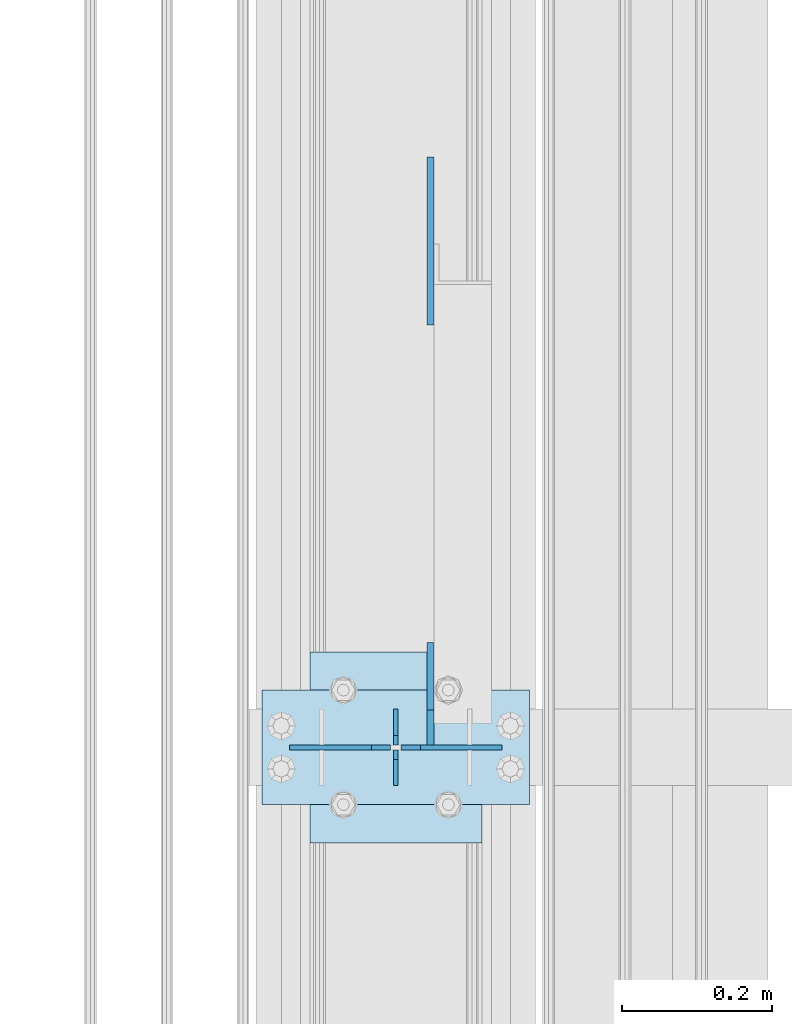
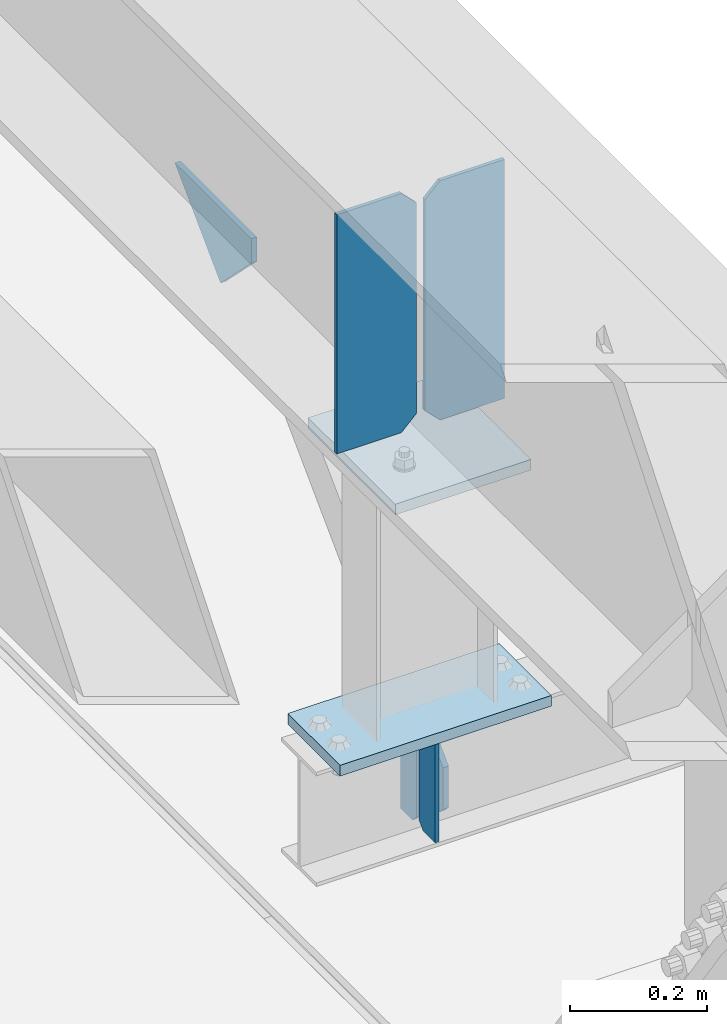
# One storey, part 3252 of 3843: 8 plates, 3 elements without a shape of their own.
"""IFC2X3 building model written with IfcOpenShell, lengths in millimetres."""

from ifc_helpers import new_model, si_unit, frame, origin_with_axes, place, context, subcontext, project, spatial, faceted_brep, material, type_object, element, aggregate, save


model = new_model("IFC2X3")

# Units and contexts
model_context = context("Model", 3, precision=1e-05, world=origin_with_axes())
body_context = subcontext(model_context, "Body", "Model", "MODEL_VIEW")
ifc_project = project(units=[si_unit("LENGTHUNIT", "METRE", prefix="MILLI"), si_unit("AREAUNIT", "SQUARE_METRE"), si_unit("VOLUMEUNIT", "CUBIC_METRE"), si_unit("MASSUNIT", "GRAM", prefix="KILO"), si_unit("TIMEUNIT", "SECOND"), si_unit("PLANEANGLEUNIT", "RADIAN"), si_unit("SOLIDANGLEUNIT", "STERADIAN"), si_unit("THERMODYNAMICTEMPERATUREUNIT", "DEGREE_CELSIUS"), si_unit("LUMINOUSINTENSITYUNIT", "LUMEN")], contexts=[model_context])

# Site, building, storey
site_placement = place(None, origin_with_axes())
site = spatial("IfcSite", under=ifc_project, at=site_placement, CompositionType="ELEMENT")
building_placement = place(site_placement, origin_with_axes())
building = spatial("IfcBuilding", under=site, at=building_placement, Name="Undefined", CompositionType="ELEMENT")
storey_placement = place(building_placement, origin_with_axes())
storey = spatial("IfcBuildingStorey", under=building, at=storey_placement, Name="Undefined", CompositionType="ELEMENT", Elevation=0.0)

# Assembly, plates
assembly_1_placement = place(storey_placement, origin_with_axes())
assembly_1 = element("IfcElementAssembly", 1, at=assembly_1_placement, inside=storey, Name="BEAM", AssemblyPlace="NOTDEFINED", PredefinedType="RIGID_FRAME")
ifc_material = material(Name="STEEL/A572-50")
plate_type_1 = type_object("IfcPlateType", PredefinedType="NOTDEFINED")
plate_1_placement = place(assembly_1_placement, frame((36576.0000030517, 51981.1, 41495.6625), z_axis=(0.0, 0.0, -1.0), x_axis=(0.0, -1.0, 0.0)))
plate_1 = element("IfcPlate", 2, at=plate_1_placement, type_object=plate_type_1, material=ifc_material, Name="PLATE", context=body_context, shape_type="Brep", body=[
    faceted_brep([(0.0, -3.17499999999927, 0.0), (0.0, -3.17500000000291, 187.324999999997), (0.0, 3.17500000000291, 187.324999999997), (0.0, 3.17499999999927, 0.0), (34.9250001907349, -3.17500000000291, 187.324999999997), (34.9250001907349, 3.17500000000291, 187.324999999997), (47.625, -3.17500000000291, 174.625000190732), (47.625, 3.17500000000291, 174.625000190732), (47.625, -3.17499999999927, 12.6999998092651), (47.625, 3.17499999999927, 12.6999998092651), (34.9250001907349, -3.17499999999927, 0.0), (34.9250001907349, 3.17499999999927, 0.0)], [[[0, 1, 2, 3]], [[1, 4, 5, 2]], [[4, 6, 7, 5]], [[6, 8, 9, 7]], [[8, 10, 11, 9]], [[10, 0, 3, 11]], [[5, 7, 9, 11, 3, 2]], [[10, 8, 6, 4, 1, 0]]]),
])
plate_2_placement = place(assembly_1_placement, frame((36576.0000030517, 51879.5, 41495.6625), z_axis=(0.0, 0.0, -1.0), x_axis=(0.0, 1.0, 0.0)))
plate_2 = element("IfcPlate", 3, at=plate_2_placement, type_object=plate_type_1, material=ifc_material, Name="PLATE", context=body_context, shape_type="Brep", body=[
    faceted_brep([(0.0, -3.17499999999927, 0.0), (0.0, -3.17500000000291, 187.324999999997), (0.0, 3.17500000000291, 187.324999999997), (0.0, 3.17499999999927, 0.0), (34.9250001907349, -3.17500000000291, 187.324999999997), (34.9250001907349, 3.17500000000291, 187.324999999997), (47.625, -3.17500000000291, 174.625000190732), (47.625, 3.17500000000291, 174.625000190732), (47.625, -3.17499999999927, 12.6999998092651), (47.625, 3.17499999999927, 12.6999998092651), (34.9250001907349, -3.17499999999927, 0.0), (34.9250001907349, 3.17499999999927, 0.0)], [[[0, 1, 2, 3]], [[1, 4, 5, 2]], [[4, 6, 7, 5]], [[6, 8, 9, 7]], [[8, 10, 11, 9]], [[10, 0, 3, 11]], [[5, 7, 9, 11, 3, 2]], [[10, 8, 6, 4, 1, 0]]]),
])

assembly_2_placement = place(storey_placement, origin_with_axes())
assembly_2 = element("IfcElementAssembly", 4, at=assembly_2_placement, inside=storey, Name="POST", AssemblyPlace="NOTDEFINED", PredefinedType="RIGID_FRAME")
plate_type_2 = type_object("IfcPlateType", PredefinedType="NOTDEFINED")
plate_3_placement = place(assembly_2_placement, frame((36753.8000030518, 51854.1, 41513.125), z_axis=(-1.0, 0.0, 0.0), x_axis=(0.0, 1.0, 0.0)))
plate_3 = element("IfcPlate", 5, at=plate_3_placement, type_object=plate_type_2, material=ifc_material, Name="PLATE", context=body_context, shape_type="Brep", body=[
    faceted_brep([(0.0, -9.52500000000146, 0.0), (0.0, -9.52500000000146, 355.599999999999), (0.0, 9.52500000000146, 355.599999999999), (0.0, 9.52500000000146, 0.0), (152.399999999994, -9.52500000000146, 355.599999999999), (152.399999999994, 9.52500000000146, 355.599999999999), (152.400000000001, -9.52500000000146, 0.0), (152.400000000001, 9.52500000000146, 0.0)], [[[0, 1, 2, 3]], [[1, 4, 5, 2]], [[4, 6, 7, 5]], [[6, 0, 3, 7]], [[5, 7, 3, 2]], [[6, 4, 1, 0]]]),
])
plate_type_3 = type_object("IfcPlateType", PredefinedType="NOTDEFINED")
plate_4_placement = place(assembly_2_placement, frame((36461.700000099, 52057.3, 41986.2), z_axis=(0.0, -1.0, 0.0), x_axis=(1.0, 0.0, 0.0)))
plate_4 = element("IfcPlate", 6, at=plate_4_placement, type_object=plate_type_3, material=ifc_material, Name="PLATE", context=body_context, shape_type="Brep", body=[
    faceted_brep([(0.0, -9.52500000000146, 0.0), (0.0, -9.52500000000146, 254.0), (0.0, 9.52500000000146, 254.0), (0.0, 9.52500000000146, 0.0), (228.599999999999, -9.52500000000146, 254.0), (228.599999999999, 9.52500000000146, 254.0), (228.599999999999, -9.52500000000146, 0.0), (228.599999999999, 9.52500000000146, 0.0)], [[[0, 1, 2, 3]], [[1, 4, 5, 2]], [[4, 6, 7, 5]], [[6, 0, 3, 7]], [[5, 7, 3, 2]], [[6, 4, 1, 0]]]),
])
aggregate(assembly_2, [plate_4, plate_3])

# Assembly, plate
assembly_3_placement = place(storey_placement, origin_with_axes())
assembly_3 = element("IfcElementAssembly", 7, at=assembly_3_placement, inside=storey, Name="BEAM", AssemblyPlace="NOTDEFINED", PredefinedType="RIGID_FRAME")
plate_type_4 = type_object("IfcPlateType", PredefinedType="NOTDEFINED")
plate_5_placement = place(assembly_3_placement, frame((36622.0375, 52715.5210226214, 41995.725), z_axis=(0.0, -0.707106781186682, 0.707106781186413), x_axis=(0.0, -0.707106781186548, -0.707106781186548)))
plate_5 = element("IfcPlate", 8, at=plate_5_placement, type_object=plate_type_4, material=ifc_material, Name="PLATE", context=body_context, shape_type="Brep", body=[
    faceted_brep([(0.0, -4.76249999999709, 0.0), (157.726597423803, -4.76249999999709, 157.726601438866), (157.726597423803, 4.76249999999709, 157.726601438866), (0.0, 4.76249999999709, 0.0), (188.387110059113, -4.76249999999709, 127.066089584019), (188.387110059113, 4.76249999999709, 127.066089584019), (188.387111679331, -4.76249999999709, 1.09139364212751e-10), (188.387111679331, 4.76249999999709, 1.09139364212751e-10)], [[[0, 1, 2, 3]], [[1, 4, 5, 2]], [[4, 6, 7, 5]], [[6, 0, 3, 7]], [[5, 7, 3, 2]], [[6, 4, 1, 0]]]),
])

# Plate
plate_type_5 = type_object("IfcPlateType", PredefinedType="NOTDEFINED")
plate_6_placement = place(assembly_1_placement, frame((36622.0375, 51933.475, 41306.75), z_axis=(0.0, 1.0, 0.0), x_axis=(0.0, 0.0, 1.0)))
plate_6 = element("IfcPlate", 9, at=plate_6_placement, type_object=plate_type_5, material=ifc_material, Name="PLATE", context=body_context, shape_type="Brep", body=[
    faceted_brep([(0.0, -4.76250000000073, 12.6999998092651), (4.450703272596e-08, -4.76249999999709, 93.0710244828806), (4.450703272596e-08, 4.76249999999709, 93.0710244828806), (0.0, 4.76250000000073, 12.6999998092651), (43.3137807601452, -4.76249999999709, 136.384805065652), (43.3137807601452, 4.76249999999709, 136.384805065652), (133.209805202001, -4.76249999999709, 46.4887805392646), (133.209805202001, 4.76249999999709, 46.4887805392646), (86.7210245267561, -4.76249999999709, 0.0), (86.7210245267561, 4.76249999999709, 0.0), (12.6999998092651, -4.76250000000073, 0.0), (12.6999998092651, 4.76250000000073, 0.0)], [[[0, 1, 2, 3]], [[1, 4, 5, 2]], [[4, 6, 7, 5]], [[6, 8, 9, 7]], [[8, 10, 11, 9]], [[10, 0, 3, 11]], [[5, 7, 9, 11, 3, 2]], [[10, 8, 6, 4, 1, 0]]]),
])

aggregate(assembly_1, [plate_1, plate_2, plate_6])

plate_type_6 = type_object("IfcPlateType", PredefinedType="NOTDEFINED")
plate_7_placement = place(assembly_3_placement, frame((36717.2875, 51930.3, 42444.9875), z_axis=(0.0, 0.0, -1.0), x_axis=(-1.0, 0.0, 0.0)))
plate_7 = element("IfcPlate", 10, at=plate_7_placement, type_object=plate_type_6, material=ifc_material, Name="PLATE", context=body_context, shape_type="Brep", body=[
    faceted_brep([(0.0, -3.17499999999927, 0.0), (0.0, -3.17500000000291, 425.449999999997), (0.0, 3.17500000000291, 425.449999999997), (0.0, 3.17499999999927, 0.0), (108.743750381465, -3.17500000000291, 425.449999999997), (108.743750381465, 3.17500000000291, 425.449999999997), (134.143749999996, -3.17500000000291, 400.050000381467), (134.143749999996, 3.17500000000291, 400.050000381467), (134.143749999996, -3.17500000000291, 25.3999996185303), (134.143749999996, 3.17500000000291, 25.3999996185303), (108.743750381465, -3.17500000000291, 0.0), (108.743750381465, 3.17500000000291, 0.0)], [[[0, 1, 2, 3]], [[1, 4, 5, 2]], [[4, 6, 7, 5]], [[6, 8, 9, 7]], [[8, 10, 11, 9]], [[10, 0, 3, 11]], [[5, 7, 9, 11, 3, 2]], [[10, 8, 6, 4, 1, 0]]]),
])

plate_8_placement = place(assembly_3_placement, frame((36434.7125, 51930.3, 42444.9875), z_axis=(0.0, 0.0, -1.0), x_axis=(1.0, 0.0, 0.0)))
plate_8 = element("IfcPlate", 11, at=plate_8_placement, type_object=plate_type_6, material=ifc_material, Name="PLATE", context=body_context, shape_type="Brep", body=[
    faceted_brep([(0.0, -3.17499999999927, 0.0), (0.0, -3.17500000000291, 425.449999999997), (0.0, 3.17500000000291, 425.449999999997), (0.0, 3.17499999999927, 0.0), (108.743750381465, -3.17500000000291, 425.449999999997), (108.743750381465, 3.17500000000291, 425.449999999997), (134.143749999996, -3.17500000000291, 400.050000381467), (134.143749999996, 3.17500000000291, 400.050000381467), (134.143749999996, -3.17500000000291, 25.3999996185303), (134.143749999996, 3.17500000000291, 25.3999996185303), (108.743750381465, -3.17500000000291, 0.0), (108.743750381465, 3.17500000000291, 0.0)], [[[0, 1, 2, 3]], [[1, 4, 5, 2]], [[4, 6, 7, 5]], [[6, 8, 9, 7]], [[8, 10, 11, 9]], [[10, 0, 3, 11]], [[5, 7, 9, 11, 3, 2]], [[10, 8, 6, 4, 1, 0]]]),
])

aggregate(assembly_3, [plate_7, plate_8, plate_5])

save(model, "model.ifc")
